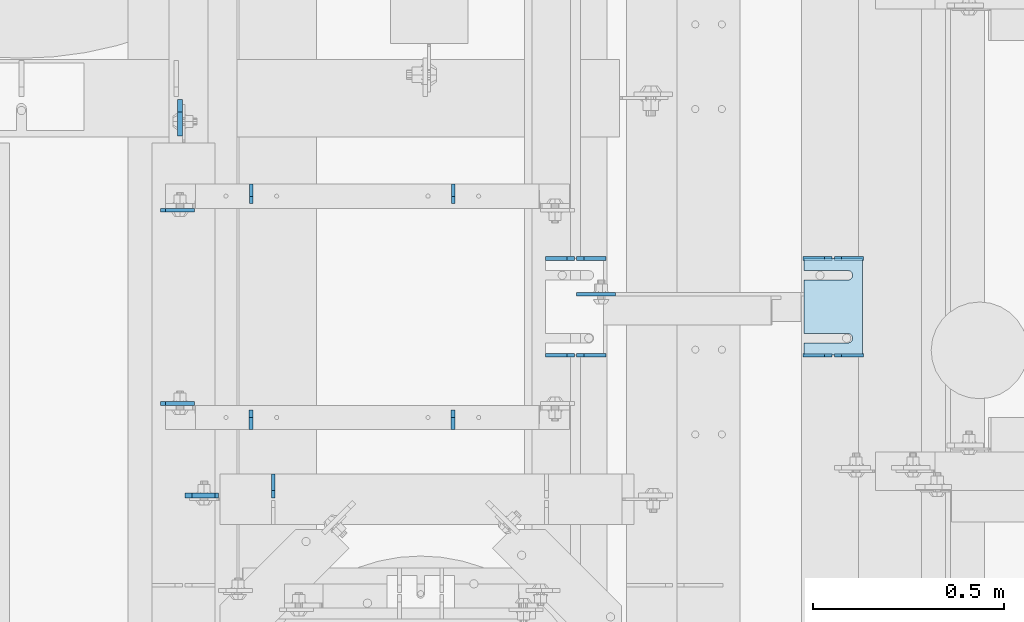
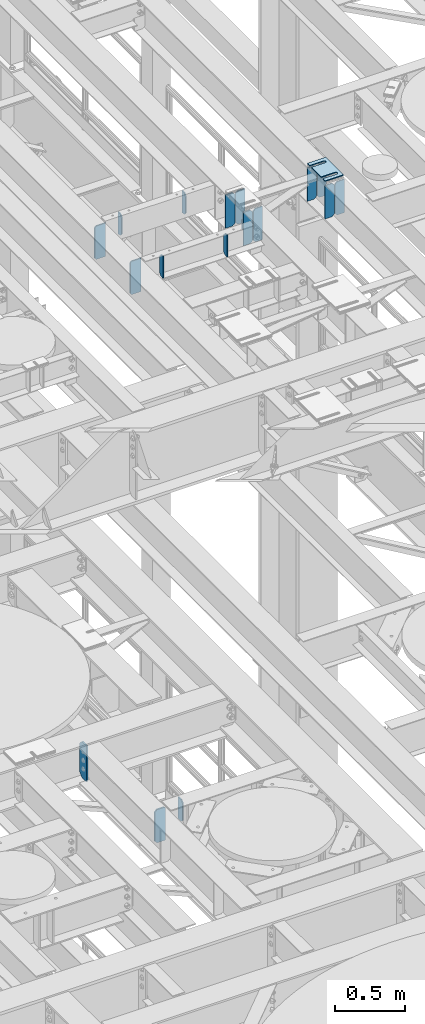
# One storey, part 1641 of 1876: 21 plates, 11 elements without a shape of their own.
"""IFC2X3 building model written with IfcOpenShell, lengths in millimetres."""

from ifc_helpers import new_model, si_unit, frame, origin_with_axes, place, context, subcontext, project, spatial, faceted_brep, material, type_object, element, aggregate, save


model = new_model("IFC2X3")

# Units and contexts
model_context = context("Model", 3, precision=1e-05, world=origin_with_axes())
body_context = subcontext(model_context, "Body", "Model", "MODEL_VIEW")
ifc_project = project(units=[si_unit("LENGTHUNIT", "METRE", prefix="MILLI"), si_unit("AREAUNIT", "SQUARE_METRE"), si_unit("VOLUMEUNIT", "CUBIC_METRE"), si_unit("MASSUNIT", "GRAM", prefix="KILO"), si_unit("TIMEUNIT", "SECOND"), si_unit("PLANEANGLEUNIT", "RADIAN"), si_unit("SOLIDANGLEUNIT", "STERADIAN"), si_unit("THERMODYNAMICTEMPERATUREUNIT", "DEGREE_CELSIUS"), si_unit("LUMINOUSINTENSITYUNIT", "LUMEN")], contexts=[model_context])

# Site, building, storey
site_placement = place(None, origin_with_axes())
site = spatial("IfcSite", under=ifc_project, at=site_placement, CompositionType="ELEMENT")
building_placement = place(site_placement, origin_with_axes())
building = spatial("IfcBuilding", under=site, at=building_placement, Name="Undefined", CompositionType="ELEMENT")
storey_placement = place(building_placement, origin_with_axes())
storey = spatial("IfcBuildingStorey", under=building, at=storey_placement, Name="Undefined", CompositionType="ELEMENT", Elevation=0.0)

# Assembly, plates
assembly_1_placement = place(storey_placement, origin_with_axes())
assembly_1 = element("IfcElementAssembly", 1, at=assembly_1_placement, inside=storey, Name="BEAM", AssemblyPlace="NOTDEFINED", PredefinedType="RIGID_FRAME")
ifc_material = material(Name="STEEL/A36")
plate_type_1 = type_object("IfcPlateType", PredefinedType="NOTDEFINED")
plate_1_placement = place(assembly_1_placement, frame((5581.65, 3428.99814883086, 17679.9875), z_axis=(0.0, 0.0, 1.0), x_axis=(-1.0, 0.0, 0.0)))
plate_1 = element("IfcPlate", 2, at=plate_1_placement, type_object=plate_type_1, material=ifc_material, Name="PLATE", context=body_context, shape_type="Brep", body=[
    faceted_brep([(0.0, -4.76249999999982, 0.0), (0.0, -4.76249999999982, 292.100006103516), (0.0, 4.76249999999982, 292.100006103516), (0.0, 4.76249999999982, 0.0), (57.1499977111816, -4.76249999999982, 292.100006103516), (57.1499977111816, 4.76249999999982, 292.100006103516), (76.1999969482422, -4.76249999999982, 273.050006866455), (76.1999969482422, 4.76249999999982, 273.050006866455), (76.1999969482422, -4.76249999999982, 19.0499992370605), (76.1999969482422, 4.76249999999982, 19.0499992370605), (57.1499977111816, -4.76249999999982, 0.0), (57.1499977111816, 4.76249999999982, 0.0)], [[[0, 1, 2, 3]], [[1, 4, 5, 2]], [[4, 6, 7, 5]], [[6, 8, 9, 7]], [[8, 10, 11, 9]], [[10, 0, 3, 11]], [[5, 7, 9, 11, 3, 2]], [[10, 8, 6, 4, 1, 0]]]),
])
plate_2_placement = place(assembly_1_placement, frame((5499.1, 3428.99814883086, 17679.9875), z_axis=(0.0, 0.0, 1.0), x_axis=(-1.0, 0.0, 0.0)))
plate_2 = element("IfcPlate", 3, at=plate_2_placement, type_object=plate_type_1, material=ifc_material, Name="PLATE", context=body_context, shape_type="Brep", body=[
    faceted_brep([(0.0, -4.76249999999982, 19.0499992370605), (0.0, -4.76249999999982, 273.050006866455), (0.0, 4.76249999999982, 273.050006866455), (0.0, 4.76249999999982, 19.0499992370605), (19.0499992370605, -4.76249999999982, 292.100006103516), (19.0499992370605, 4.76249999999982, 292.100006103516), (76.1999969482422, -4.76249999999982, 292.100006103516), (76.1999969482422, 4.76249999999982, 292.100006103516), (76.1999969482422, -4.76250000000073, 0.0), (76.1999969482422, 4.76250000000073, 0.0), (19.0499992370605, -4.76249999999982, 0.0), (19.0499992370605, 4.76249999999982, 0.0)], [[[0, 1, 2, 3]], [[1, 4, 5, 2]], [[4, 6, 7, 5]], [[6, 8, 9, 7]], [[8, 10, 11, 9]], [[10, 0, 3, 11]], [[5, 7, 9, 11, 3, 2]], [[10, 8, 6, 4, 1, 0]]]),
])
plate_3_placement = place(assembly_1_placement, frame((5581.65, 3682.99768875065, 17679.9875), z_axis=(0.0, 0.0, 1.0), x_axis=(-1.0, 0.0, 0.0)))
plate_3 = element("IfcPlate", 4, at=plate_3_placement, type_object=plate_type_1, material=ifc_material, Name="PLATE", context=body_context, shape_type="Brep", body=[
    faceted_brep([(0.0, -4.76249999999982, 0.0), (0.0, -4.76249999999982, 292.100006103516), (0.0, 4.76249999999982, 292.100006103516), (0.0, 4.76249999999982, 0.0), (57.1499977111816, -4.76249999999982, 292.100006103516), (57.1499977111816, 4.76249999999982, 292.100006103516), (76.1999969482422, -4.76249999999982, 273.050006866455), (76.1999969482422, 4.76249999999982, 273.050006866455), (76.1999969482422, -4.76249999999982, 19.0499992370605), (76.1999969482422, 4.76249999999982, 19.0499992370605), (57.1499977111816, -4.76249999999982, 0.0), (57.1499977111816, 4.76249999999982, 0.0)], [[[0, 1, 2, 3]], [[1, 4, 5, 2]], [[4, 6, 7, 5]], [[6, 8, 9, 7]], [[8, 10, 11, 9]], [[10, 0, 3, 11]], [[5, 7, 9, 11, 3, 2]], [[10, 8, 6, 4, 1, 0]]]),
])
plate_4_placement = place(assembly_1_placement, frame((5499.1, 3682.99768875065, 17679.9875), z_axis=(0.0, 0.0, 1.0), x_axis=(-1.0, 0.0, 0.0)))
plate_4 = element("IfcPlate", 5, at=plate_4_placement, type_object=plate_type_1, material=ifc_material, Name="PLATE", context=body_context, shape_type="Brep", body=[
    faceted_brep([(0.0, -4.76249999999982, 19.0499992370605), (0.0, -4.76249999999982, 273.050006866455), (0.0, 4.76249999999982, 273.050006866455), (0.0, 4.76249999999982, 19.0499992370605), (19.0499992370605, -4.76249999999982, 292.100006103516), (19.0499992370605, 4.76249999999982, 292.100006103516), (76.1999969482422, -4.76249999999982, 292.100006103516), (76.1999969482422, 4.76249999999982, 292.100006103516), (76.1999969482422, -4.76250000000073, 0.0), (76.1999969482422, 4.76250000000073, 0.0), (19.0499992370605, -4.76249999999982, 0.0), (19.0499992370605, 4.76249999999982, 0.0)], [[[0, 1, 2, 3]], [[1, 4, 5, 2]], [[4, 6, 7, 5]], [[6, 8, 9, 7]], [[8, 10, 11, 9]], [[10, 0, 3, 11]], [[5, 7, 9, 11, 3, 2]], [[10, 8, 6, 4, 1, 0]]]),
])
aggregate(assembly_1, [plate_1, plate_2, plate_3, plate_4])

assembly_2_placement = place(storey_placement, origin_with_axes())
assembly_2 = element("IfcElementAssembly", 6, at=assembly_2_placement, inside=storey, Name="BEAM", AssemblyPlace="NOTDEFINED", PredefinedType="RIGID_FRAME")
plate_5_placement = place(assembly_2_placement, frame((4905.375, 3428.99814839992, 17681.575), z_axis=(0.0, 0.0, 1.0), x_axis=(-1.0, 0.0, 0.0)))
plate_5 = element("IfcPlate", 7, at=plate_5_placement, type_object=plate_type_1, material=ifc_material, Name="PLATE", context=body_context, shape_type="Brep", body=[
    faceted_brep([(0.0, -4.76249999999982, 0.0), (0.0, -4.76249999999982, 292.100006103516), (0.0, 4.76249999999982, 292.100006103516), (0.0, 4.76249999999982, 0.0), (57.1499977111816, -4.76249999999982, 292.100006103516), (57.1499977111816, 4.76249999999982, 292.100006103516), (76.1999969482422, -4.76249999999982, 273.050006866455), (76.1999969482422, 4.76249999999982, 273.050006866455), (76.1999969482422, -4.76249999999982, 19.0499992370605), (76.1999969482422, 4.76249999999982, 19.0499992370605), (57.1499977111816, -4.76249999999982, 0.0), (57.1499977111816, 4.76249999999982, 0.0)], [[[0, 1, 2, 3]], [[1, 4, 5, 2]], [[4, 6, 7, 5]], [[6, 8, 9, 7]], [[8, 10, 11, 9]], [[10, 0, 3, 11]], [[5, 7, 9, 11, 3, 2]], [[10, 8, 6, 4, 1, 0]]]),
])
plate_6_placement = place(assembly_2_placement, frame((4822.825, 3428.99814839992, 17681.575), z_axis=(0.0, 0.0, 1.0), x_axis=(-1.0, 0.0, 0.0)))
plate_6 = element("IfcPlate", 8, at=plate_6_placement, type_object=plate_type_1, material=ifc_material, Name="PLATE", context=body_context, shape_type="Brep", body=[
    faceted_brep([(0.0, -4.76249999999982, 19.0499992370605), (0.0, -4.76249999999982, 273.050006866455), (0.0, 4.76249999999982, 273.050006866455), (0.0, 4.76249999999982, 19.0499992370605), (19.0499992370605, -4.76249999999982, 292.100006103516), (19.0499992370605, 4.76249999999982, 292.100006103516), (76.1999969482422, -4.76249999999982, 292.100006103516), (76.1999969482422, 4.76249999999982, 292.100006103516), (76.1999969482422, -4.76250000000073, 0.0), (76.1999969482422, 4.76250000000073, 0.0), (19.0499992370605, -4.76249999999982, 0.0), (19.0499992370605, 4.76249999999982, 0.0)], [[[0, 1, 2, 3]], [[1, 4, 5, 2]], [[4, 6, 7, 5]], [[6, 8, 9, 7]], [[8, 10, 11, 9]], [[10, 0, 3, 11]], [[5, 7, 9, 11, 3, 2]], [[10, 8, 6, 4, 1, 0]]]),
])
plate_7_placement = place(assembly_2_placement, frame((4905.375, 3682.99768844013, 17681.575), z_axis=(0.0, 0.0, 1.0), x_axis=(-1.0, 0.0, 0.0)))
plate_7 = element("IfcPlate", 9, at=plate_7_placement, type_object=plate_type_1, material=ifc_material, Name="PLATE", context=body_context, shape_type="Brep", body=[
    faceted_brep([(0.0, -4.76249999999982, 0.0), (0.0, -4.76249999999982, 292.100006103516), (0.0, 4.76249999999982, 292.100006103516), (0.0, 4.76249999999982, 0.0), (57.1499977111816, -4.76249999999982, 292.100006103516), (57.1499977111816, 4.76249999999982, 292.100006103516), (76.1999969482422, -4.76249999999982, 273.050006866455), (76.1999969482422, 4.76249999999982, 273.050006866455), (76.1999969482422, -4.76249999999982, 19.0499992370605), (76.1999969482422, 4.76249999999982, 19.0499992370605), (57.1499977111816, -4.76249999999982, 0.0), (57.1499977111816, 4.76249999999982, 0.0)], [[[0, 1, 2, 3]], [[1, 4, 5, 2]], [[4, 6, 7, 5]], [[6, 8, 9, 7]], [[8, 10, 11, 9]], [[10, 0, 3, 11]], [[5, 7, 9, 11, 3, 2]], [[10, 8, 6, 4, 1, 0]]]),
])
plate_8_placement = place(assembly_2_placement, frame((4822.825, 3682.99768844013, 17681.575), z_axis=(0.0, 0.0, 1.0), x_axis=(-1.0, 0.0, 0.0)))
plate_8 = element("IfcPlate", 10, at=plate_8_placement, type_object=plate_type_1, material=ifc_material, Name="PLATE", context=body_context, shape_type="Brep", body=[
    faceted_brep([(0.0, -4.76249999999982, 19.0499992370605), (0.0, -4.76249999999982, 273.050006866455), (0.0, 4.76249999999982, 273.050006866455), (0.0, 4.76249999999982, 19.0499992370605), (19.0499992370605, -4.76249999999982, 292.100006103516), (19.0499992370605, 4.76249999999982, 292.100006103516), (76.1999969482422, -4.76249999999982, 292.100006103516), (76.1999969482422, 4.76249999999982, 292.100006103516), (76.1999969482422, -4.76250000000073, 0.0), (76.1999969482422, 4.76250000000073, 0.0), (19.0499992370605, -4.76249999999982, 0.0), (19.0499992370605, 4.76249999999982, 0.0)], [[[0, 1, 2, 3]], [[1, 4, 5, 2]], [[4, 6, 7, 5]], [[6, 8, 9, 7]], [[8, 10, 11, 9]], [[10, 0, 3, 11]], [[5, 7, 9, 11, 3, 2]], [[10, 8, 6, 4, 1, 0]]]),
])

# Assembly, plate
assembly_3_placement = place(storey_placement, origin_with_axes())
assembly_3 = element("IfcElementAssembly", 11, at=assembly_3_placement, inside=storey, Name="BEAM", AssemblyPlace="NOTDEFINED", PredefinedType="RIGID_FRAME")
plate_type_2 = type_object("IfcPlateType", PredefinedType="NOTDEFINED")
plate_9_placement = place(assembly_3_placement, frame((4032.25, 3054.35, 13111.1625), z_axis=(0.0, 0.0, 1.0), x_axis=(0.0, 1.0, 0.0)))
plate_9 = element("IfcPlate", 12, at=plate_9_placement, type_object=plate_type_2, material=ifc_material, Name="PLATE", context=body_context, shape_type="Brep", body=[
    faceted_brep([(0.0, -4.76249999999982, 19.0499992370605), (0.0, -4.76249999999982, 171.450000762939), (0.0, 4.76249999999982, 171.450000762939), (0.0, 4.76249999999982, 19.0499992370605), (19.0499992370605, -4.76249999999982, 190.5), (19.0499992370605, 4.76249999999982, 190.5), (63.5, -4.76249999999982, 190.5), (63.5, 4.76249999999982, 190.5), (63.5, -4.76249999999982, 0.0), (63.5, 4.76249999999982, 0.0), (19.0499992370605, -4.76249999999982, 0.0), (19.0499992370605, 4.76249999999982, 0.0)], [[[0, 1, 2, 3]], [[1, 4, 5, 2]], [[4, 6, 7, 5]], [[6, 8, 9, 7]], [[8, 10, 11, 9]], [[10, 0, 3, 11]], [[5, 7, 9, 11, 3, 2]], [[10, 8, 6, 4, 1, 0]]]),
])
aggregate(assembly_3, [plate_9])

# Assembly, plates
assembly_4_placement = place(storey_placement, origin_with_axes())
assembly_4 = element("IfcElementAssembly", 13, at=assembly_4_placement, inside=storey, Name="BEAM", AssemblyPlace="NOTDEFINED", PredefinedType="RIGID_FRAME")
plate_type_3 = type_object("IfcPlateType", PredefinedType="NOTDEFINED")
plate_10_placement = place(assembly_4_placement, frame((3736.975, 3302.19893691608, 17681.575), z_axis=(0.0, 0.0, 1.0), x_axis=(1.0, 0.0, 0.0)))
plate_10 = element("IfcPlate", 14, at=plate_10_placement, type_object=plate_type_3, material=ifc_material, Name="PLATE", context=body_context, shape_type="Brep", body=[
    faceted_brep([(3.7040990719106e-08, -4.76249999999982, 12.6999998092651), (0.0, -4.76249999999982, 279.40000629425), (0.0, 4.76249999999982, 279.40000629425), (3.70396264770534e-08, 4.76249999999982, 12.6999998092651), (12.6999998092651, -4.76249999999982, 292.100006103516), (12.6999998092651, 4.76249999999982, 292.100006103516), (88.9000015258789, -4.76249999999982, 292.100006103516), (88.9000015258789, 4.76249999999982, 292.100006103516), (88.9000015258789, -4.76249999999982, 0.0), (88.9000015258789, 4.76249999999982, 0.0), (12.699999809267, -4.76249999999754, 1.09139364212751e-11), (12.6999998092651, 4.76250000000255, 1.09139364212751e-11)], [[[0, 1, 2, 3]], [[1, 4, 5, 2]], [[4, 6, 7, 5]], [[6, 8, 9, 7]], [[8, 10, 11, 9]], [[10, 0, 3, 11]], [[5, 7, 9, 11, 3, 2]], [[10, 8, 6, 4, 1, 0]]]),
])
plate_11_placement = place(assembly_4_placement, frame((3736.975, 3809.80106308392, 17681.575), z_axis=(0.0, 0.0, 1.0), x_axis=(1.0, 0.0, 0.0)))
plate_11 = element("IfcPlate", 15, at=plate_11_placement, type_object=plate_type_3, material=ifc_material, Name="PLATE", context=body_context, shape_type="Brep", body=[
    faceted_brep([(3.7040990719106e-08, -4.76249999999982, 12.6999998092651), (0.0, -4.76249999999982, 279.40000629425), (0.0, 4.76249999999982, 279.40000629425), (3.70396264770534e-08, 4.76249999999982, 12.6999998092651), (12.6999998092651, -4.76249999999982, 292.100006103516), (12.6999998092651, 4.76249999999982, 292.100006103516), (88.9000015258789, -4.76249999999982, 292.100006103516), (88.9000015258789, 4.76249999999982, 292.100006103516), (88.9000015258789, -4.76249999999982, 0.0), (88.9000015258789, 4.76249999999982, 0.0), (12.699999809267, -4.76249999999754, 1.09139364212751e-11), (12.6999998092651, 4.76250000000255, 1.09139364212751e-11)], [[[0, 1, 2, 3]], [[1, 4, 5, 2]], [[4, 6, 7, 5]], [[6, 8, 9, 7]], [[8, 10, 11, 9]], [[10, 0, 3, 11]], [[5, 7, 9, 11, 3, 2]], [[10, 8, 6, 4, 1, 0]]]),
])
aggregate(assembly_4, [plate_10, plate_11])

# Plate
plate_type_4 = type_object("IfcPlateType", PredefinedType="NOTDEFINED")
plate_12_placement = place(assembly_2_placement, frame((4829.17444174189, 3589.33547079771, 17780.0934066252), z_axis=(1.0, 0.0, 0.0), x_axis=(0.0, 0.0, -1.0)))
plate_12 = element("IfcPlate", 16, at=plate_12_placement, type_object=plate_type_4, material=ifc_material, Name="PLATE", context=body_context, shape_type="Brep", body=[
    faceted_brep([(0.0, -4.76249999999982, 0.0), (0.0, -4.76250000001255, 102.325820922852), (0.0, 4.76249999998754, 102.325820922853), (0.0, 4.76249999999982, 0.0), (98.5184097290039, -4.76250000001255, 102.325820922852), (98.5184097290039, 4.76249999998754, 102.325820922853), (98.5184097290039, -4.76250000000164, 19.0499992370587), (98.5184097290039, 4.76249999999845, 19.0499992370605), (79.4684104919434, -4.76249999999936, -9.09494701772928e-13), (79.4684104919434, 4.76250000000027, 0.0)], [[[0, 1, 2, 3]], [[1, 4, 5, 2]], [[4, 6, 7, 5]], [[6, 8, 9, 7]], [[8, 0, 3, 9]], [[5, 7, 9, 3, 2]], [[8, 6, 4, 1, 0]]]),
])

aggregate(assembly_2, [plate_5, plate_6, plate_7, plate_8, plate_12])

# Assembly, plate
assembly_5_placement = place(storey_placement, origin_with_axes())
assembly_5 = element("IfcElementAssembly", 17, at=assembly_5_placement, inside=storey, Name="BEAM", AssemblyPlace="NOTDEFINED", PredefinedType="RIGID_FRAME")
plate_type_5 = type_object("IfcPlateType", PredefinedType="NOTDEFINED")
plate_13_placement = place(assembly_5_placement, frame((3800.475, 3060.70000009537, 13007.975), z_axis=(0.0, 0.0, 1.0), x_axis=(1.0, 0.0, 0.0)))
plate_13 = element("IfcPlate", 18, at=plate_13_placement, type_object=plate_type_5, material=ifc_material, Name="PLATE", context=body_context, shape_type="Brep", body=[
    faceted_brep([(0.0, -6.35000000000036, 271.462512969971), (19.0499992370605, -6.35000000000036, 290.512512207031), (19.0499992370605, 6.35000000000036, 290.512512207031), (0.0, 6.35000000000036, 271.462512969971), (0.0, -6.35000000000196, 19.0499992370605), (0.0, 6.35000000000105, 19.0499992370605), (19.0499992370642, -6.35000000000105, 0.0), (19.0499992370633, 6.35000000000105, 0.0), (88.9000015258789, -6.34999999999991, 0.0), (88.9000015258789, 6.34999999999991, 0.0), (88.9000015258789, -6.34999999999991, 280.987512151783), (79.3749874887271, -6.35000000000036, 290.512512207031), (79.3749874887271, 6.35000000000036, 290.512512207031), (88.9000015258789, 6.34999999999991, 280.987512151783)], [[[0, 1, 2, 3]], [[4, 0, 3, 5]], [[6, 4, 5, 7]], [[8, 6, 7, 9]], [[1, 0, 4, 6, 8, 10, 11]], [[2, 1, 11, 12]], [[9, 7, 5, 3, 2, 12, 13]], [[8, 9, 13, 10]], [[12, 11, 10, 13]]]),
])
aggregate(assembly_5, [plate_13])

assembly_6_placement = place(storey_placement, origin_with_axes())
assembly_6 = element("IfcElementAssembly", 19, at=assembly_6_placement, inside=storey, Name="BEAM", AssemblyPlace="NOTDEFINED", PredefinedType="RIGID_FRAME")
plate_type_6 = type_object("IfcPlateType", PredefinedType="NOTDEFINED")
plate_14_placement = place(assembly_6_placement, frame((3787.77499990463, 4099.71875, 12977.8125), z_axis=(0.0, 0.0, 1.0), x_axis=(0.0, -1.0, 0.0)))
plate_14 = element("IfcPlate", 20, at=plate_14_placement, type_object=plate_type_6, material=ifc_material, Name="PLATE", context=body_context, shape_type="Brep", body=[
    faceted_brep([(0.0, -6.34999999999991, 31.75), (-1.81898940354586e-12, -6.34999999999991, 284.162506103516), (1.81898940354586e-12, 6.35000000000173, 284.162506103516), (0.0, 6.34999999999991, 31.75), (31.7499999999927, -6.34999999999991, 315.912506103516), (31.7499999999982, 6.35000000000309, 315.912506103516), (95.25, -6.35000000000036, 315.912506103516), (95.25, 6.35000000000036, 315.912506103516), (95.25, -6.35000000000036, 0.0), (95.25, 6.35000000000036, 0.0), (31.75, -6.34999999999991, 0.0), (31.75, 6.34999999999991, 0.0)], [[[0, 1, 2, 3]], [[1, 4, 5, 2]], [[4, 6, 7, 5]], [[6, 8, 9, 7]], [[8, 10, 11, 9]], [[10, 0, 3, 11]], [[5, 7, 9, 11, 3, 2]], [[10, 8, 6, 4, 1, 0]]]),
])
aggregate(assembly_6, [plate_14])

assembly_7_placement = place(storey_placement, origin_with_axes())
assembly_7 = element("IfcElementAssembly", 21, at=assembly_7_placement, inside=storey, Name="SHIM PLATE", AssemblyPlace="NOTDEFINED", PredefinedType="RIGID_FRAME")
plate_type_7 = type_object("IfcPlateType", PredefinedType="NOTDEFINED")
plate_15_placement = place(assembly_7_placement, frame((5578.71798271492, 3428.99813842842, 18009.3925), z_axis=(-1.0, 0.0, 0.0), x_axis=(0.0, 1.0, 0.0)))
plate_15 = element("IfcPlate", 22, at=plate_15_placement, type_object=plate_type_7, material=ifc_material, Name="SHIM PLATE", context=body_context, shape_type="Brep", body=[
    faceted_brep([(31.7473236467022, -0.793499999999767, 152.398895263674), (31.7495452849444, -0.793499999999767, 38.0994505459066), (31.7495452849444, 0.793499999999767, 38.0994505459066), (31.7473236467022, 0.793499999999767, 152.398895263674), (33.4510181364694, -0.793499999999767, 31.7494480392982), (33.4510181364694, 0.793499999999767, 31.7494480392982), (38.0995388011806, -0.793499999999767, 27.1009216783834), (38.0995388011806, 0.793499999999767, 27.1009216783834), (44.4495392228328, -0.793499999999767, 25.3994410457015), (44.4495392228328, 0.793499999999767, 25.3994410457015), (50.7995409628356, -0.793499999999767, 27.1009167582527), (50.7995409628356, 0.793499999999767, 27.1009167582527), (55.4480652293469, -0.793499999999767, 31.7494395173824), (55.4480652293469, 0.793499999999767, 31.7494395173824), (57.14954300102, -0.793499999999767, 38.0994407056476), (57.14954300102, 0.793499999999767, 38.0994407056476), (57.1473213626687, -0.793499999999767, 152.398894419415), (57.1473213626687, 0.793499999999767, 152.398895263676), (9.09494701772928e-13, -0.793499999999767, 0.0), (1.98268335225293e-05, -0.793499999999767, 152.398895263672), (1.98268335225293e-05, 0.793499999999767, 152.398895263672), (9.09494701772928e-13, 0.793499999999767, 0.0), (253.999542236328, -0.793499999999767, 6.16182660451159e-11), (253.999542236328, 0.793499999999767, 6.16182660451159e-11), (253.999557495107, -0.793499999999767, 152.398895263688), (253.999557495107, 0.793499999999767, 152.398895263688), (222.247321362667, 0.793499999999767, 152.398895263686), (222.247321362667, -0.793499999999767, 152.398895410166), (222.249543001019, 0.793499999999767, 38.0994416963979), (222.249543001019, -0.793499999999767, 38.0994416963979), (220.548065229345, 0.793499999999767, 31.7494405081325), (220.548065229345, -0.793499999999767, 31.7494405081325), (215.899540962834, 0.793499999999767, 27.100917749003), (215.899540962834, -0.793499999999767, 27.100917749003), (209.549539222831, 0.793499999999767, 25.3994420364518), (209.549539222831, -0.793499999999767, 25.3994420364518), (203.199538801179, 0.793499999999767, 27.1009226691335), (203.199538801179, -0.793499999999767, 27.1009226691335), (198.551018136468, 0.793499999999767, 31.7494490300483), (198.551018136468, -0.793499999999767, 31.7494490300483), (196.849545284943, 0.793499999999767, 38.0994515366567), (196.849545284943, -0.793499999999767, 38.0994515366567), (196.847323646701, -0.793499999999767, 152.398895263684), (196.847323646701, 0.793499999999767, 152.398895263684)], [[[0, 1, 2, 3]], [[4, 5, 2, 1]], [[6, 7, 5, 4]], [[8, 9, 7, 6]], [[10, 11, 9, 8]], [[12, 13, 11, 10]], [[14, 15, 13, 12]], [[16, 17, 15, 14]], [[18, 19, 20, 21]], [[22, 18, 21, 23]], [[24, 22, 23, 25]], [[24, 25, 26, 27]], [[27, 26, 28, 29]], [[29, 28, 30, 31]], [[31, 30, 32, 33]], [[33, 32, 34, 35]], [[35, 34, 36, 37]], [[37, 36, 38, 39]], [[39, 38, 40, 41]], [[42, 41, 40, 43]], [[12, 10, 8, 6, 4, 1, 0, 19, 18, 22, 24, 27, 29, 31, 33, 35, 37, 39, 41, 42, 16, 14]], [[20, 19, 0, 3]], [[43, 40, 38, 36, 34, 32, 30, 28, 26, 25, 23, 21, 20, 3, 2, 5, 7, 9, 11, 13, 15, 17]], [[42, 43, 17, 16]]]),
])
aggregate(assembly_7, [plate_15])

assembly_8_placement = place(storey_placement, origin_with_axes())
assembly_8 = element("IfcElementAssembly", 23, at=assembly_8_placement, inside=storey, Name="SHIM PLATE", AssemblyPlace="NOTDEFINED", PredefinedType="RIGID_FRAME")
plate_type_8 = type_object("IfcPlateType", PredefinedType="NOTDEFINED")
plate_16_placement = place(assembly_8_placement, frame((5578.71798271446, 3428.99813842828, 18007.0115), z_axis=(-1.0, 0.0, 0.0), x_axis=(0.0, 1.0, 0.0)))
plate_16 = element("IfcPlate", 24, at=plate_16_placement, type_object=plate_type_8, material=ifc_material, Name="SHIM PLATE", context=body_context, shape_type="Brep", body=[
    faceted_brep([(31.7473236467022, -1.58750000000146, 152.398895263674), (31.7495452849444, -1.58750000000146, 38.0994505459066), (31.7495452849444, 1.58750000000146, 38.0994505459066), (31.7473236467022, 1.58750000000146, 152.398895263674), (33.4510181364694, -1.58750000000146, 31.7494480392982), (33.4510181364694, 1.58750000000146, 31.7494480392982), (38.0995388011806, -1.58750000000146, 27.1009216783834), (38.0995388011806, 1.58750000000146, 27.1009216783834), (44.4495392228328, -1.58750000000146, 25.3994410457015), (44.4495392228328, 1.58750000000146, 25.3994410457015), (50.7995409628356, -1.58750000000146, 27.1009167582527), (50.7995409628356, 1.58750000000146, 27.1009167582527), (55.4480652293469, -1.58750000000146, 31.7494395173824), (55.4480652293469, 1.58750000000146, 31.7494395173824), (57.14954300102, -1.58750000000146, 38.0994407056476), (57.14954300102, 1.58750000000146, 38.0994407056476), (57.1473213626687, -1.58750000000146, 152.398894419415), (57.1473213626687, 1.58750000000146, 152.398895263676), (9.09494701772928e-13, -1.58750000000146, 4.54747350886464e-13), (1.98264133359771e-05, -1.58750000000146, 152.398895263672), (1.98264133359771e-05, 1.58750000000146, 152.398895263672), (9.09494701772928e-13, 1.58750000000146, 4.54747350886464e-13), (253.999542236328, -1.58750000000146, 6.16182660451159e-11), (253.999542236328, 1.58750000000146, 6.16182660451159e-11), (253.999557495107, -1.58750000000146, 152.398895263688), (253.999557495107, 1.58750000000146, 152.398895263688), (222.247321362667, 1.58750000000146, 152.398895263686), (222.247321362667, -1.58750000000146, 152.398895410166), (222.249543001019, 1.58750000000146, 38.0994416963979), (222.249543001019, -1.58750000000146, 38.0994416963979), (220.548065229345, 1.58750000000146, 31.7494405081325), (220.548065229345, -1.58750000000146, 31.7494405081325), (215.899540962834, 1.58750000000146, 27.100917749003), (215.899540962834, -1.58750000000146, 27.100917749003), (209.549539222831, 1.58750000000146, 25.3994420364518), (209.549539222831, -1.58750000000146, 25.3994420364518), (203.199538801179, 1.58750000000146, 27.1009226691335), (203.199538801179, -1.58750000000146, 27.1009226691335), (198.551018136468, 1.58750000000146, 31.7494490300483), (198.551018136468, -1.58750000000146, 31.7494490300483), (196.849545284943, 1.58750000000146, 38.0994515366567), (196.849545284943, -1.58750000000146, 38.0994515366567), (196.847323646701, -1.58750000000146, 152.398895263684), (196.847323646701, 1.58750000000146, 152.398895263684)], [[[0, 1, 2, 3]], [[4, 5, 2, 1]], [[6, 7, 5, 4]], [[8, 9, 7, 6]], [[10, 11, 9, 8]], [[12, 13, 11, 10]], [[14, 15, 13, 12]], [[16, 17, 15, 14]], [[18, 19, 20, 21]], [[22, 18, 21, 23]], [[24, 22, 23, 25]], [[24, 25, 26, 27]], [[27, 26, 28, 29]], [[29, 28, 30, 31]], [[31, 30, 32, 33]], [[33, 32, 34, 35]], [[35, 34, 36, 37]], [[37, 36, 38, 39]], [[39, 38, 40, 41]], [[42, 41, 40, 43]], [[12, 10, 8, 6, 4, 1, 0, 19, 18, 22, 24, 27, 29, 31, 33, 35, 37, 39, 41, 42, 16, 14]], [[20, 19, 0, 3]], [[43, 40, 38, 36, 34, 32, 30, 28, 26, 25, 23, 21, 20, 3, 2, 5, 7, 9, 11, 13, 15, 17]], [[42, 43, 17, 16]]]),
])
aggregate(assembly_8, [plate_16])

assembly_9_placement = place(storey_placement, origin_with_axes())
assembly_9 = element("IfcElementAssembly", 25, at=assembly_9_placement, inside=storey, Name="SHIM PLATE", AssemblyPlace="NOTDEFINED", PredefinedType="RIGID_FRAME")
plate_17_placement = place(assembly_9_placement, frame((5578.717982714, 3428.99813842815, 18003.8365), z_axis=(-1.0, 0.0, 0.0), x_axis=(0.0, 1.0, 0.0)))
plate_17 = element("IfcPlate", 26, at=plate_17_placement, type_object=plate_type_8, material=ifc_material, Name="SHIM PLATE", context=body_context, shape_type="Brep", body=[
    faceted_brep([(31.7473236467022, -1.58750000000146, 152.398895263674), (31.7495452849444, -1.58750000000146, 38.0994505459066), (31.7495452849444, 1.58750000000146, 38.0994505459066), (31.7473236467022, 1.58750000000146, 152.398895263674), (33.4510181364694, -1.58750000000146, 31.7494480392982), (33.4510181364694, 1.58750000000146, 31.7494480392982), (38.0995388011806, -1.58750000000146, 27.1009216783834), (38.0995388011806, 1.58750000000146, 27.1009216783834), (44.4495392228328, -1.58750000000146, 25.3994410457015), (44.4495392228328, 1.58750000000146, 25.3994410457015), (50.7995409628356, -1.58750000000146, 27.1009167582527), (50.7995409628356, 1.58750000000146, 27.1009167582527), (55.4480652293469, -1.58750000000146, 31.7494395173824), (55.4480652293469, 1.58750000000146, 31.7494395173824), (57.14954300102, -1.58750000000146, 38.0994407056476), (57.14954300102, 1.58750000000146, 38.0994407056476), (57.1473213626687, -1.58750000000146, 152.398894419415), (57.1473213626687, 1.58750000000146, 152.398895263676), (9.09494701772928e-13, -1.58750000000146, 4.54747350886464e-13), (1.98264133359771e-05, -1.58750000000146, 152.398895263672), (1.98264133359771e-05, 1.58750000000146, 152.398895263672), (9.09494701772928e-13, 1.58750000000146, 4.54747350886464e-13), (253.999542236328, -1.58750000000146, 6.16182660451159e-11), (253.999542236328, 1.58750000000146, 6.16182660451159e-11), (253.999557495107, -1.58750000000146, 152.398895263688), (253.999557495107, 1.58750000000146, 152.398895263688), (222.247321362667, 1.58750000000146, 152.398895263686), (222.247321362667, -1.58750000000146, 152.398895410166), (222.249543001019, 1.58750000000146, 38.0994416963979), (222.249543001019, -1.58750000000146, 38.0994416963979), (220.548065229345, 1.58750000000146, 31.7494405081325), (220.548065229345, -1.58750000000146, 31.7494405081325), (215.899540962834, 1.58750000000146, 27.100917749003), (215.899540962834, -1.58750000000146, 27.100917749003), (209.549539222831, 1.58750000000146, 25.3994420364518), (209.549539222831, -1.58750000000146, 25.3994420364518), (203.199538801179, 1.58750000000146, 27.1009226691335), (203.199538801179, -1.58750000000146, 27.1009226691335), (198.551018136468, 1.58750000000146, 31.7494490300483), (198.551018136468, -1.58750000000146, 31.7494490300483), (196.849545284943, 1.58750000000146, 38.0994515366567), (196.849545284943, -1.58750000000146, 38.0994515366567), (196.847323646701, -1.58750000000146, 152.398895263684), (196.847323646701, 1.58750000000146, 152.398895263684)], [[[0, 1, 2, 3]], [[4, 5, 2, 1]], [[6, 7, 5, 4]], [[8, 9, 7, 6]], [[10, 11, 9, 8]], [[12, 13, 11, 10]], [[14, 15, 13, 12]], [[16, 17, 15, 14]], [[18, 19, 20, 21]], [[22, 18, 21, 23]], [[24, 22, 23, 25]], [[24, 25, 26, 27]], [[27, 26, 28, 29]], [[29, 28, 30, 31]], [[31, 30, 32, 33]], [[33, 32, 34, 35]], [[35, 34, 36, 37]], [[37, 36, 38, 39]], [[39, 38, 40, 41]], [[42, 41, 40, 43]], [[12, 10, 8, 6, 4, 1, 0, 19, 18, 22, 24, 27, 29, 31, 33, 35, 37, 39, 41, 42, 16, 14]], [[20, 19, 0, 3]], [[43, 40, 38, 36, 34, 32, 30, 28, 26, 25, 23, 21, 20, 3, 2, 5, 7, 9, 11, 13, 15, 17]], [[42, 43, 17, 16]]]),
])
aggregate(assembly_9, [plate_17])

# Assembly, plates
assembly_10_placement = place(storey_placement, origin_with_axes())
assembly_10 = element("IfcElementAssembly", 27, at=assembly_10_placement, inside=storey, Name="BEAM", AssemblyPlace="NOTDEFINED", PredefinedType="RIGID_FRAME")
plate_type_9 = type_object("IfcPlateType", PredefinedType="NOTDEFINED")
plate_18_placement = place(assembly_10_placement, frame((4504.63199500581, 3284.735937, 17970.50127), z_axis=(0.0, -0.164335003932507, -0.986404585594827), x_axis=(0.0, -0.986404585594827, 0.164335003932507)))
plate_18 = element("IfcPlate", 28, at=plate_18_placement, type_object=plate_type_9, material=ifc_material, Name="PLATE", context=body_context, shape_type="Brep", body=[
    faceted_brep([(-3.13088156866024, -4.76249999999982, 18.7909566423405), (-26.0909240038113, -4.76249999999982, 156.592771384876), (-26.0909240038113, 4.76249999999982, 156.592771384876), (-3.13088156866024, 4.76249999999982, 18.7909566423405), (-11.2008338947639, -4.76249999999982, 181.560057902076), (-11.2008338947639, 4.76249999999982, 181.560057902076), (19.4964675903825, -4.76249999999982, 192.080947875766), (19.4964675903825, 4.76249999999982, 192.080947875766), (51.5003013610922, -4.76249999999982, -8.36735125631094e-11), (51.5003013610922, 4.76249999999982, -8.36735125631094e-11), (19.0499992370605, -4.76249999999982, 0.0), (19.0499992370605, 4.76249999999982, 0.0)], [[[0, 1, 2, 3]], [[1, 4, 5, 2]], [[4, 6, 7, 5]], [[6, 8, 9, 7]], [[8, 10, 11, 9]], [[10, 0, 3, 11]], [[5, 7, 9, 11, 3, 2]], [[10, 8, 6, 4, 1, 0]]]),
])
plate_19_placement = place(assembly_10_placement, frame((3974.40699500581, 3284.735937, 17970.50127), z_axis=(0.0, -0.164335003932507, -0.986404585594827), x_axis=(0.0, -0.986404585594827, 0.164335003932507)))
plate_19 = element("IfcPlate", 29, at=plate_19_placement, type_object=plate_type_9, material=ifc_material, Name="PLATE", context=body_context, shape_type="Brep", body=[
    faceted_brep([(-3.13088156866024, -4.76249999999982, 18.7909566423405), (-26.0909240038113, -4.76249999999982, 156.592771384876), (-26.0909240038113, 4.76249999999982, 156.592771384876), (-3.13088156866024, 4.76249999999982, 18.7909566423405), (-11.2008338947639, -4.76249999999982, 181.560057902076), (-11.2008338947639, 4.76249999999982, 181.560057902076), (19.4964675903825, -4.76249999999982, 192.080947875766), (19.4964675903825, 4.76249999999982, 192.080947875766), (51.5003013610922, -4.76249999999982, -8.36735125631094e-11), (51.5003013610922, 4.76249999999982, -8.36735125631094e-11), (19.0499992370605, -4.76249999999982, 0.0), (19.0499992370605, 4.76249999999982, 0.0)], [[[0, 1, 2, 3]], [[1, 4, 5, 2]], [[4, 6, 7, 5]], [[6, 8, 9, 7]], [[8, 10, 11, 9]], [[10, 0, 3, 11]], [[5, 7, 9, 11, 3, 2]], [[10, 8, 6, 4, 1, 0]]]),
])
aggregate(assembly_10, [plate_18, plate_19])

assembly_11_placement = place(storey_placement, origin_with_axes())
assembly_11 = element("IfcElementAssembly", 30, at=assembly_11_placement, inside=storey, Name="BEAM", AssemblyPlace="NOTDEFINED", PredefinedType="RIGID_FRAME")
plate_20_placement = place(assembly_11_placement, frame((3975.09993973152, 3878.064063, 17978.96455), z_axis=(0.0, 0.164335003932503, -0.986404585594828), x_axis=(0.0, -0.986404585594828, -0.164335003932504)))
plate_20 = element("IfcPlate", 31, at=plate_20_placement, type_object=plate_type_9, material=ifc_material, Name="PLATE", context=body_context, shape_type="Brep", body=[
    faceted_brep([(0.0, -4.76249999999982, 0.0), (32.0008087158794, -4.76249999999982, 192.081680297815), (32.0008087158794, 4.76249999999982, 192.081680297815), (0.0, 4.76249999999982, 0.0), (62.6982748962027, -4.76249999999982, 181.561281061485), (62.6982748962027, 4.76249999999982, 181.561281061485), (77.5887637589458, -4.76249999999982, 156.594231983478), (77.5887637589458, 4.76249999999982, 156.594231983478), (54.6307491805464, -4.76249999999982, 18.791006663906), (54.6307491805464, 4.76249999999982, 18.791006663906), (32.4501686096137, -4.76249999999982, -1.63709046319127e-11), (32.4501686096137, 4.76249999999982, -1.63709046319127e-11)], [[[0, 1, 2, 3]], [[1, 4, 5, 2]], [[4, 6, 7, 5]], [[6, 8, 9, 7]], [[8, 10, 11, 9]], [[10, 0, 3, 11]], [[5, 7, 9, 11, 3, 2]], [[10, 8, 6, 4, 1, 0]]]),
])
plate_21_placement = place(assembly_11_placement, frame((4504.92806473151, 3878.064063, 17978.369238), z_axis=(0.0, 0.164335003932503, -0.986404585594828), x_axis=(0.0, -0.986404585594828, -0.164335003932504)))
plate_21 = element("IfcPlate", 32, at=plate_21_placement, type_object=plate_type_9, material=ifc_material, Name="PLATE", context=body_context, shape_type="Brep", body=[
    faceted_brep([(0.0, -4.76249999999982, 0.0), (32.0008087158794, -4.76249999999982, 192.081680297815), (32.0008087158794, 4.76249999999982, 192.081680297815), (0.0, 4.76249999999982, 0.0), (62.6982748962027, -4.76249999999982, 181.561281061485), (62.6982748962027, 4.76249999999982, 181.561281061485), (77.5887637589458, -4.76249999999982, 156.594231983478), (77.5887637589458, 4.76249999999982, 156.594231983478), (54.6307491805464, -4.76249999999982, 18.791006663906), (54.6307491805464, 4.76249999999982, 18.791006663906), (32.4501686096137, -4.76249999999982, -1.63709046319127e-11), (32.4501686096137, 4.76249999999982, -1.63709046319127e-11)], [[[0, 1, 2, 3]], [[1, 4, 5, 2]], [[4, 6, 7, 5]], [[6, 8, 9, 7]], [[8, 10, 11, 9]], [[10, 0, 3, 11]], [[5, 7, 9, 11, 3, 2]], [[10, 8, 6, 4, 1, 0]]]),
])
aggregate(assembly_11, [plate_20, plate_21])

save(model, "model.ifc")
